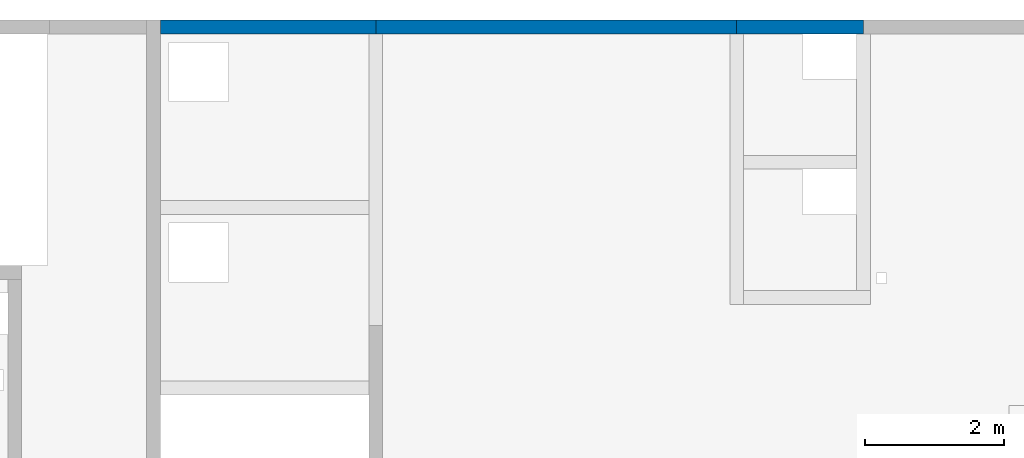
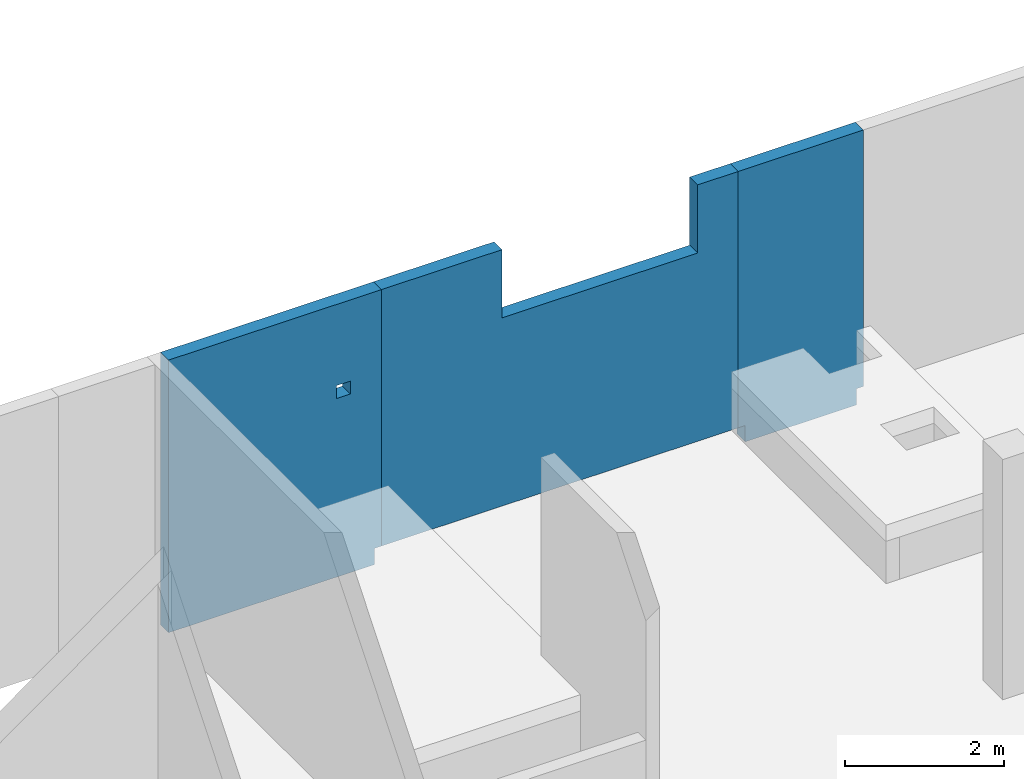
# One storey, part 4 of 6: 3 walls, 2 openings.
"""IFC4 building model written with IfcOpenShell, lengths in millimetres."""

from ifc_helpers import new_model, entity, si_unit, converted_unit, derived_unit, direction, frame, origin, place, context, subcontext, project, spatial, indexed_curve, outline, extrude, polygons, material, type_object, element, save


model = new_model("IFC4")

# Units and contexts
model_context = context("Model", 3, precision=0.01, world=origin(), true_north=direction((6.12303176911189e-17, 1.0)))
plan_context = context("Plan", 3, precision=0.01, world=origin(), true_north=direction((6.12303176911189e-17, 1.0)))
body_context = subcontext(model_context, "Body", "Model", "MODEL_VIEW")
ifc_project = project(units=[si_unit("LENGTHUNIT", "METRE", prefix="MILLI"), si_unit("AREAUNIT", "SQUARE_METRE"), si_unit("VOLUMEUNIT", "CUBIC_METRE"), converted_unit("PLANEANGLEUNIT", "DEGREE", entity("IfcRatioMeasure", 0.0174532925199433), si_unit("PLANEANGLEUNIT", "RADIAN"), dimensions=[0, 0, 0, 0, 0, 0, 0]), si_unit("MASSUNIT", "GRAM", prefix="KILO"), derived_unit("MASSDENSITYUNIT", [(si_unit("MASSUNIT", "GRAM", prefix="KILO"), 1), (si_unit("LENGTHUNIT", "METRE"), -3)]), derived_unit("MOMENTOFINERTIAUNIT", [(si_unit("LENGTHUNIT", "METRE"), 4)]), si_unit("TIMEUNIT", "SECOND"), si_unit("FREQUENCYUNIT", "HERTZ"), si_unit("THERMODYNAMICTEMPERATUREUNIT", "DEGREE_CELSIUS"), derived_unit("THERMALTRANSMITTANCEUNIT", [(si_unit("MASSUNIT", "GRAM", prefix="KILO"), 1), (si_unit("THERMODYNAMICTEMPERATUREUNIT", "KELVIN"), -1), (si_unit("TIMEUNIT", "SECOND"), -3)]), derived_unit("VOLUMETRICFLOWRATEUNIT", [(si_unit("LENGTHUNIT", "METRE"), 3), (si_unit("TIMEUNIT", "SECOND"), -1)]), derived_unit("MASSFLOWRATEUNIT", [(si_unit("MASSUNIT", "GRAM", prefix="KILO"), 1), (si_unit("TIMEUNIT", "SECOND"), -1)]), derived_unit("ROTATIONALFREQUENCYUNIT", [(si_unit("TIMEUNIT", "SECOND"), -1)]), si_unit("ELECTRICCURRENTUNIT", "AMPERE"), si_unit("ELECTRICVOLTAGEUNIT", "VOLT"), si_unit("POWERUNIT", "WATT"), si_unit("FORCEUNIT", "NEWTON", prefix="KILO"), si_unit("ILLUMINANCEUNIT", "LUX"), si_unit("LUMINOUSFLUXUNIT", "LUMEN"), si_unit("LUMINOUSINTENSITYUNIT", "CANDELA"), derived_unit("USERDEFINED", [(si_unit("MASSUNIT", "GRAM", prefix="KILO"), -1), (si_unit("LENGTHUNIT", "METRE"), -2), (si_unit("TIMEUNIT", "SECOND"), 3), (si_unit("LUMINOUSFLUXUNIT", "LUMEN"), 1)]), derived_unit("LINEARVELOCITYUNIT", [(si_unit("LENGTHUNIT", "METRE"), 1), (si_unit("TIMEUNIT", "SECOND"), -1)]), si_unit("PRESSUREUNIT", "PASCAL"), derived_unit("USERDEFINED", [(si_unit("LENGTHUNIT", "METRE"), -2), (si_unit("MASSUNIT", "GRAM", prefix="KILO"), 1), (si_unit("TIMEUNIT", "SECOND"), -2)]), derived_unit("LINEARFORCEUNIT", [(si_unit("MASSUNIT", "GRAM", prefix="KILO"), 1), (si_unit("LENGTHUNIT", "METRE"), 1), (si_unit("TIMEUNIT", "SECOND"), -2), (si_unit("LENGTHUNIT", "METRE"), -1)]), derived_unit("PLANARFORCEUNIT", [(si_unit("MASSUNIT", "GRAM", prefix="KILO"), 1), (si_unit("LENGTHUNIT", "METRE"), 1), (si_unit("TIMEUNIT", "SECOND"), -2), (si_unit("LENGTHUNIT", "METRE"), -2)])], contexts=[model_context, plan_context])

# Site, building, storey
site_placement = place(None, origin())
site = spatial("IfcSite", under=ifc_project, at=site_placement, CompositionType="ELEMENT")
building_placement = place(site_placement, origin())
building = spatial("IfcBuilding", under=site, at=building_placement, CompositionType="ELEMENT")
storey_placement = place(building_placement, frame((0.0, 0.0, 28200.0)))
storey = spatial("IfcBuildingStorey", under=building, at=storey_placement, CompositionType="ELEMENT", Elevation=28200.0)

# Wall, opening
ifc_material = material()
wall_type = type_object("IfcWallType", PredefinedType="STANDARD")
wall_1_placement = place(storey_placement, frame((7700.0002685547, 20399.9998657227, -400.0)))
wall_1 = element("IfcWall", 1, at=wall_1_placement, inside=storey, type_object=wall_type, material=ifc_material, PredefinedType="NOTDEFINED", context=body_context, shape_type="Tessellation", body=[
    polygons([(3099.99999999999, -99.9999999999989, 4200.0), (-1.44381896161168e-13, -99.9999999999989, 4200.0), (-1.44381896161168e-13, -99.9999999999989, 1150.0), (-1.44381896161168e-13, -99.9999999999989, 899.999999999999), (-1.44381896161168e-13, -99.9999999999989, 249.999999999999), (-1.44381896161168e-13, -99.9999999999989, 0.0), (3000.0, -99.9999999999989, 0.0), (3000.0, -99.9999999999989, 249.999999999999), (3099.99999999999, -99.9999999999989, 249.999999999999), (2449.99999999998, -99.9999999999989, 2950.0), (2649.99999999998, -99.9999999999989, 2950.0), (2649.99999999998, -99.9999999999989, 2750.00000000001), (2449.99999999998, -99.9999999999989, 2750.00000000001), (-7.21911031786967e-13, 99.9999999999989, 4200.0), (3099.99999999999, 99.9999999999989, 4200.0), (3099.99999999999, 99.9999999999989, 249.999999999999), (3000.0, 99.9999999999946, 249.999999999999), (3000.0, 99.9999999999989, 0.0), (-7.21911031786967e-13, 99.9999999999989, 0.0), (-7.21911031786967e-13, 99.9999999999989, 249.999999999999), (2649.99999999998, 100.000000000319, 2950.0), (2449.99999999998, 100.000000000319, 2950.0), (2449.99999999998, 100.000000000319, 2750.00000000001), (2649.99999999998, 100.000000000319, 2750.00000000001)], [[[1, 2, 3, 4, 5, 6, 7, 8, 9], [10, 11, 12, 13]], [[14, 15, 16, 17, 18, 19, 20], [21, 22, 23, 24]], [[6, 19, 18, 7]], [[2, 1, 15, 14]], [[2, 14, 20, 19, 6, 5, 4, 3]], [[15, 1, 9, 16]], [[8, 17, 16, 9]], [[17, 8, 7, 18]], [[22, 21, 11, 10]], [[22, 10, 13, 23]], [[23, 13, 12, 24]], [[11, 21, 24, 12]]], closed=True),
])
opening_1_placement = place(wall_1_placement, frame((-7700.0002685547, -20399.9998657227, 400.0)))
element("IfcOpeningElement", 2, at=opening_1_placement, cuts=wall_1, PredefinedType="OPENING", context=body_context, shape_type="SweptSolid", body=[
    extrude(outline(indexed_curve([(-99.9999999999946, -99.9999999999989), (99.9999999999903, -99.9999999999989), (99.9999999999903, 100.000000000001), (-99.9999999999946, 100.000000000001), (-99.9999999999946, -99.9999999999989)], self_intersect=False)), frame((10250.0002685547, 20299.9998657227, 2450.0), z_axis=(0.0, 1.0, 0.0), x_axis=(0.0, 0.0, -1.0)), (0.0, 0.0, 1.0), 200.000000000959),
])

# Wall
wall_2_placement = place(storey_placement, frame((16000.0002685547, 20399.9998657227, -400.0)))
element("IfcWall", 3, at=wall_2_placement, inside=storey, type_object=wall_type, material=ifc_material, PredefinedType="NOTDEFINED", context=body_context, shape_type="Tessellation", body=[
    polygons([(1824.99999999998, -99.9999999999989, 4200.0), (3.33193465125452e-14, -99.9999999999989, 4200.0), (3.33193465125452e-14, -99.9999999999989, 249.999999999999), (99.9999999999925, -99.9999999999989, 249.999999999999), (99.9999999999925, -99.9999999999989, 0.0), (1724.99999999999, -99.9999999999989, 0.0), (1724.99999999999, -99.9999999999989, 249.999999999999), (1824.99999999998, -99.9999999999989, 249.999999999999), (-4.997844709882e-13, 99.9999999999989, 4200.0), (1824.99999999998, 99.9999999999989, 4200.0), (1824.99999999998, 99.9999999999989, 249.999999999999), (1724.99999999999, 100.000000000051, 249.999999999999), (1724.99999999999, 99.9999999999989, 0.0), (99.9999999999919, 99.9999999999989, 0.0), (99.9999999999919, 99.9999999999946, 249.999999999999), (-4.997844709882e-13, 99.9999999999989, 249.999999999999)], [[[1, 2, 3, 4, 5, 6, 7, 8]], [[9, 10, 11, 12, 13, 14, 15, 16]], [[6, 5, 14, 13]], [[2, 1, 10, 9]], [[2, 9, 16, 3]], [[10, 1, 8, 11]], [[15, 4, 3, 16]], [[4, 15, 14, 5]], [[12, 7, 6, 13]], [[7, 12, 11, 8]]], closed=True),
])

# Wall, opening
wall_3_placement = place(storey_placement, frame((10800.0002685547, 20399.9998657227, -150.0)))
wall_3 = element("IfcWall", 4, at=wall_3_placement, inside=storey, type_object=wall_type, material=ifc_material, PredefinedType="NOTDEFINED", context=body_context, shape_type="Tessellation", body=[
    polygons([(-1.60424329067794e-13, -99.9999999999989, 0.0), (100.000000000001, -99.9999999999989, 0.0), (5100.00000000003, -99.9999999999989, 0.0), (5200.00000000003, -99.9999999999989, 0.0), (5200.00000000003, -99.9999999999989, 3950.0), (4610.00000000002, -99.9999999999989, 3950.0), (4610.00000000002, -100.000000000319, 2900.00000000001), (1760.00000000002, -100.000000000319, 2900.00000000001), (1760.00000000002, -99.9999999999989, 3950.0), (-1.60424329067794e-13, -99.9999999999989, 3950.0), (5200.00000000003, 99.9999999999989, 0.0), (-8.02123368652022e-13, 99.9999999999989, 0.0), (-8.02123368652022e-13, 99.9999999999989, 3950.0), (1760.00000000002, 99.9999999999989, 3950.0), (1760.00000000002, 99.9999999999989, 2900.00000000001), (4610.00000000002, 99.9999999999989, 2900.00000000002), (4610.00000000002, 99.9999999999989, 3950.0), (5200.00000000003, 99.9999999999989, 3950.0)], [[[1, 2, 3, 4, 5, 6, 7, 8, 9, 10]], [[11, 12, 13, 14, 15, 16, 17, 18]], [[4, 3, 2, 1, 12, 11]], [[5, 18, 17, 6]], [[10, 13, 12, 1]], [[4, 11, 18, 5]], [[16, 7, 6, 17]], [[7, 16, 15, 8]], [[8, 15, 14, 9]], [[13, 10, 9, 14]]], closed=True),
])
opening_2_placement = place(wall_3_placement, frame((-10800.0002685547, -20399.9998657227, 150.0)))
element("IfcOpeningElement", 5, at=opening_2_placement, cuts=wall_3, PredefinedType="OPENING", context=body_context, shape_type="SweptSolid", body=[
    extrude(outline(indexed_curve([(-1425.0, -524.999999999993), (1425.0, -524.999999999993), (1425.0, 524.999999999993), (-1425.0, 524.999999999993), (-1425.0, -524.999999999993)], self_intersect=False)), frame((13985.0002685547, 20299.9998657217, 3275.0), z_axis=(0.0, 1.0, 0.0), x_axis=(1.0, 0.0, 0.0)), (0.0, 0.0, 1.0), 200.000000000959),
])

save(model, "model.ifc")
